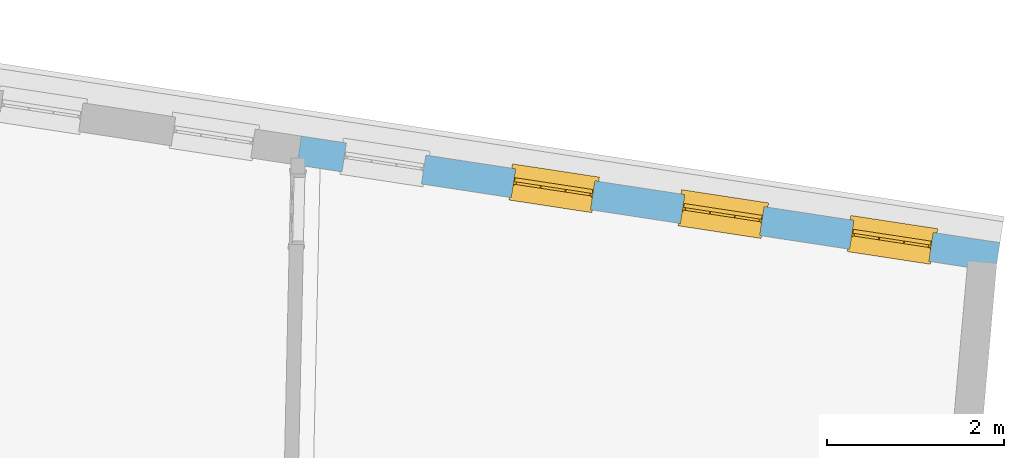
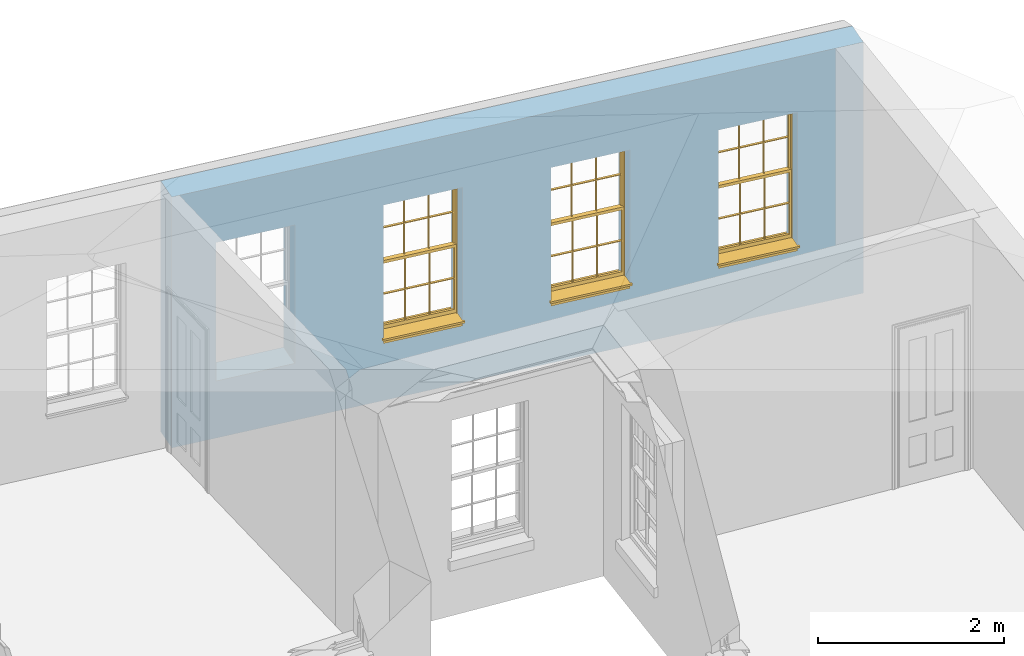
# One storey, part 9 of 12: 3 windows, 4 openings, plus 1 element that does not belong to this part.
"""IFC2X3 building model written with IfcOpenShell, lengths in metres."""

from ifc_helpers import new_model, si_unit, frame, origin, place, context, subcontext, project, spatial, polyline, outline, extrude, faceted_brep, material, layer, layer_set, layer_usage, element, fill, save


model = new_model("IFC2X3")

# Units and contexts
model_context = context("Model", 3, world=origin())
body_context = subcontext(model_context, "Body", "Model", "MODEL_VIEW")
ifc_project = project(units=[si_unit("PLANEANGLEUNIT", "RADIAN"), si_unit("MASSUNIT", "GRAM", prefix="KILO"), si_unit("FORCEUNIT", "NEWTON", prefix="KILO"), si_unit("LENGTHUNIT", "METRE")], contexts=[model_context])

# Site, building, storey
site_placement = place(None, origin())
site = spatial("IfcSite", under=ifc_project, at=site_placement, CompositionType="ELEMENT")
building_placement = place(None, origin())
building = spatial("IfcBuilding", under=site, at=building_placement, Name="Building plot-18", CompositionType="ELEMENT")
storey_placement = place(None, frame((0.0, 0.0, 9.9)))
storey = spatial("IfcBuildingStorey", under=building, at=storey_placement, Name="Floor 2", CompositionType="ELEMENT", Elevation=9.9)

# Wall, openings, windows
ifc_material = material(Name="Masonry")
ifc_layer = layer(ifc_material, 0.33, ventilated=False)
ifc_layer_set = layer_set([ifc_layer], Name="My Wall")
ifc_layer_usage = layer_usage(ifc_layer_set, "AXIS2", "NEGATIVE", 0.08)
wall_placement = place(storey_placement, origin())
wall = element("IfcWallStandardCase", 1, at=wall_placement, inside=storey, material=ifc_layer_usage, Name="exterior", context=body_context, shape_type="SweptSolid", body=[
    extrude(outline(polyline([(101.941775393575, 24.4390124661107), (101.991519769301, 24.7652416755381), (94.0844961381432, 25.9709275645287), (94.0347517624171, 25.6446983551013), (101.941775393575, 24.4390124661107)])), origin(), (0.0, 0.0, 1.0), 3.3),
])
opening_1_placement = place(storey_placement, frame((0.0, 0.0, 0.75)))
opening_1 = element("IfcOpeningElement", 2, at=opening_1_placement, cuts=wall, Name="Opening", ObjectType="Opening", context=body_context, shape_type="SweptSolid", body=[
    extrude(outline(polyline([(101.236692272156, 24.880339960858), (100.337090512825, 25.017513845436), (100.287346137099, 24.6912846360086), (101.186947896429, 24.5541107514306), (101.236692272156, 24.880339960858)])), origin(), (0.0, 0.0, 1.0), 1.82),
])
opening_2_placement = place(storey_placement, frame((0.0, 0.0, 0.75)))
opening_2 = element("IfcOpeningElement", 3, at=opening_2_placement, cuts=wall, Name="Opening", ObjectType="Opening", context=body_context, shape_type="SweptSolid", body=[
    extrude(outline(polyline([(99.3217221994849, 25.1723401498242), (98.4221204401548, 25.3095140344022), (98.3723760644287, 24.9832848249748), (99.2719778237588, 24.8461109403968), (99.3217221994849, 25.1723401498242)])), origin(), (0.0, 0.0, 1.0), 1.82),
])
opening_3_placement = place(storey_placement, frame((0.0, 0.0, 0.75)))
opening_3 = element("IfcOpeningElement", 4, at=opening_3_placement, cuts=wall, Name="Opening", ObjectType="Opening", context=body_context, shape_type="SweptSolid", body=[
    extrude(outline(polyline([(97.4067521268142, 25.4643403387904), (96.5071503674841, 25.6015142233684), (96.4574059917581, 25.275285013941), (97.3570077510882, 25.138111129363), (97.4067521268142, 25.4643403387904)])), origin(), (0.0, 0.0, 1.0), 1.82),
])
opening_4_placement = place(storey_placement, frame((0.0, 0.0, 0.75)))
element("IfcOpeningElement", 5, at=opening_4_placement, cuts=wall, Name="Opening", ObjectType="Opening", context=body_context, shape_type="SweptSolid", body=[
    extrude(outline(polyline([(95.4917820541436, 25.7563405277566), (94.5921802948135, 25.8935144123346), (94.5424359190874, 25.5672852029072), (95.4420376784175, 25.4301113183292), (95.4917820541436, 25.7563405277566)])), origin(), (0.0, 0.0, 1.0), 1.82),
])
window_1_placement = place(storey_placement, frame((101.19900713903, 24.6331966203827, 0.75), z_axis=(0.0, 0.0, 1.0), x_axis=(-0.899601759330096, 0.13717388457793, 0.0)))
window_1 = element("IfcWindow", 6, at=window_1_placement, inside=storey, Name="circulation outside window", OverallHeight=1.82, OverallWidth=0.91, context=body_context, shape_type="Brep", held_by="IfcProductRepresentation", body=[
    faceted_brep([(0.033125, -0.105, 0.975209), (0.01, -0.105, 0.975209), (0.033125, -0.105, 1.376042), (0.876875, -0.105, 0.975209), (0.876875, -0.105, 1.376042), (0.9, -0.105, 0.975209), (0.876875, -0.105, 1.386042), (0.876875, -0.105, 1.786875), (0.9, -0.105, 1.81), (0.033125, -0.105, 1.786875), (0.033125, -0.105, 1.386042), (0.01, -0.105, 1.81), (0.876875, -0.135, 1.376042), (0.876875, -0.135, 0.975209), (0.9, -0.135, 0.937083), (0.033125, -0.135, 1.786875), (0.01, -0.135, 1.81), (0.033125, -0.135, 1.386042), (0.01, -0.135, 0.937083), (0.033125, -0.135, 0.975209), (0.033125, -0.135, 1.376042), (0.876875, -0.135, 1.786875), (0.876875, -0.135, 1.386042), (0.9, -0.135, 1.81), (0.033125, -0.105, 0.937083), (0.01, -0.105, 0.937083), (0.033125, -0.105, 0.53625), (0.876875, -0.105, 0.937083), (0.876875, -0.105, 0.53625), (0.9, -0.105, 0.937083), (0.876875, -0.105, 0.52625), (0.876875, -0.105, 0.125417), (0.9, -0.105, 0.077167), (0.033125, -0.105, 0.125417), (0.033125, -0.105, 0.52625), (0.01, -0.105, 0.077167), (-0.0425, -0.25, 0.01), (-0.0425, -0.3, 0.001667), (0.0, -0.25, 0.01), (0.9525, -0.25, 0.01), (0.91, -0.25, 0.01), (0.9525, -0.3, 0.001667), (-0.02, 0.08, 0.077167), (0.0, 0.08, 0.077167), (-0.02, 0.11, 0.077167), (0.0, -0.06, 0.077167), (0.01, -0.06, 0.077167), (0.91, -0.06, 0.077167), (0.91, 0.08, 0.077167), (0.9, -0.06, 0.077167), (0.93, 0.08, 0.077167), (0.93, 0.11, 0.077167), (0.01, -0.075, 0.975209), (0.9, -0.075, 0.975209), (0.876875, -0.075, 0.125417), (0.876875, -0.075, 0.52625), (0.9, -0.075, 0.077167), (0.876875, -0.075, 0.53625), (0.876875, -0.075, 0.937083), (0.033125, -0.075, 0.125417), (0.01, -0.075, 0.077167), (0.033125, -0.075, 0.52625), (0.033125, -0.075, 0.937083), (0.033125, -0.075, 0.53625), (-0.02, 0.08, 0.052167), (-0.02, 0.11, 0.052167), (0.93, 0.11, 0.052167), (0.93, 0.08, 0.052167), (0.91, 0.08, 0.052167), (0.0, 0.08, 0.052167), (0.91, -0.15, 0.026667), (0.0, -0.15, 0.026667), (-0.0425, -0.3, -0.123333), (0.9525, -0.3, -0.123333), (-0.0425, -0.25, -0.123333), (0.9525, -0.25, -0.123333), (0.01, -0.06, 1.81), (0.9, -0.06, 1.81), (0.0, -0.06, 1.82), (0.91, -0.06, 1.82), (0.01, -0.15, 0.077167), (0.9, -0.15, 0.077167), (0.592292, -0.105, 0.125417), (0.592292, -0.075, 0.125417), (0.317708, -0.075, 0.125417), (0.317708, -0.105, 0.125417), (0.592292, -0.105, 0.53625), (0.317708, -0.105, 0.53625), (0.317708, -0.105, 0.52625), (0.592292, -0.105, 0.52625), (0.592292, -0.075, 0.53625), (0.317708, -0.075, 0.53625), (0.592292, -0.135, 1.386042), (0.592292, -0.105, 1.386042), (0.317708, -0.105, 1.386042), (0.317708, -0.135, 1.386042), (0.317708, -0.135, 1.376042), (0.592292, -0.135, 1.376042), (0.317708, -0.105, 1.376042), (0.592292, -0.105, 1.376042), (0.602292, -0.135, 1.376042), (0.592292, -0.135, 0.975209), (0.602292, -0.135, 0.975209), (0.602292, -0.105, 0.975209), (0.592292, -0.105, 0.975209), (0.602292, -0.105, 1.376042), (0.602292, -0.075, 0.53625), (0.602292, -0.105, 0.53625), (0.317708, -0.075, 0.52625), (0.307708, -0.075, 0.125417), (0.307708, -0.075, 0.52625), (0.602292, -0.075, 0.52625), (0.602292, -0.075, 0.125417), (0.592292, -0.075, 0.52625), (0.307708, -0.075, 0.53625), (0.317708, -0.075, 0.937083), (0.307708, -0.075, 0.937083), (0.602292, -0.075, 0.937083), (0.592292, -0.075, 0.937083), (0.307708, -0.105, 0.52625), (0.307708, -0.105, 0.125417), (0.307708, -0.105, 0.53625), (0.307708, -0.105, 0.937083), (0.592292, -0.105, 0.937083), (0.317708, -0.105, 0.937083), (0.602292, -0.105, 0.937083), (0.602292, -0.105, 0.52625), (0.602292, -0.105, 0.125417), (0.307708, -0.135, 1.386042), (0.307708, -0.135, 1.376042), (0.307708, -0.135, 0.975209), (0.317708, -0.135, 0.975209), (0.317708, -0.135, 1.786875), (0.307708, -0.135, 1.786875), (0.602292, -0.135, 1.786875), (0.592292, -0.135, 1.786875), (0.602292, -0.135, 1.386042), (0.602292, -0.105, 1.386042), (0.307708, -0.105, 1.386042), (0.307708, -0.105, 1.786875), (0.317708, -0.105, 1.786875), (0.592292, -0.105, 1.786875), (0.602292, -0.105, 1.786875), (0.307708, -0.105, 1.376042), (0.317708, -0.105, 0.975209), (0.307708, -0.105, 0.975209), (0.91, -0.15, 1.82), (0.9, -0.15, 1.81), (0.01, -0.15, 1.81), (0.0, -0.15, 1.82), (0.91, -0.25, 0.0), (0.0, -0.25, 0.0), (0.91, 0.08, 0.0), (0.0, 0.08, 0.0)], [[[0, 1, 2]], [[3, 4, 5]], [[6, 7, 8]], [[9, 10, 11]], [[12, 13, 14]], [[15, 16, 17]], [[18, 19, 20]], [[21, 22, 23]], [[24, 25, 26]], [[27, 28, 29]], [[30, 31, 32]], [[33, 34, 35]], [[14, 27, 29]], [[25, 24, 18]], [[36, 37, 38]], [[39, 40, 41]], [[42, 43, 44]], [[45, 46, 43]], [[47, 48, 49]], [[50, 51, 48]], [[1, 0, 52]], [[5, 53, 3]], [[54, 55, 56]], [[57, 58, 53]], [[59, 60, 61]], [[62, 63, 52]], [[48, 43, 46, 49]], [[51, 44, 43, 48]], [[64, 42, 44, 65]], [[65, 44, 51, 66]], [[66, 51, 50, 67]], [[65, 66, 68, 69]], [[60, 56, 49, 46]], [[70, 71, 38, 40]], [[37, 41, 40, 38]], [[37, 72, 73, 41]], [[74, 75, 73, 72]], [[8, 11, 76, 77]], [[76, 78, 79, 77]], [[32, 35, 80, 81]], [[81, 80, 71, 70]], [[82, 83, 84, 85]], [[86, 87, 88, 89]], [[86, 90, 91, 87]], [[92, 93, 94, 95]], [[92, 95, 96, 97]], [[96, 98, 99, 97]], [[100, 97, 101, 102]], [[103, 104, 99, 105]], [[97, 99, 104, 101]], [[102, 103, 105, 100]], [[28, 57, 106, 107]], [[108, 84, 109, 110]], [[111, 112, 83, 113]], [[114, 110, 61, 63]], [[90, 113, 108, 91]], [[115, 91, 114, 116]], [[117, 106, 90, 118]], [[111, 106, 57, 55]], [[119, 110, 109, 120]], [[34, 61, 110, 119]], [[89, 113, 83, 82]], [[88, 108, 113, 89]], [[85, 84, 108, 88]], [[121, 114, 63, 26]], [[122, 116, 114, 121]], [[123, 118, 90, 86]], [[87, 91, 115, 124]], [[107, 106, 117, 125]], [[126, 111, 55, 30]], [[127, 112, 111, 126]], [[126, 30, 28, 107]], [[88, 119, 120, 85]], [[126, 89, 82, 127]], [[125, 123, 86, 107]], [[121, 26, 34, 119]], [[124, 122, 121, 87]], [[128, 17, 20, 129]], [[96, 129, 130, 131]], [[132, 133, 128, 95]], [[134, 135, 92, 136]], [[100, 12, 22, 136]], [[137, 6, 4, 105]], [[94, 138, 139, 140]], [[137, 93, 141, 142]], [[99, 98, 94, 93]], [[143, 2, 10, 138]], [[144, 145, 143, 98]], [[129, 143, 145, 130]], [[20, 2, 143, 129]], [[131, 144, 98, 96]], [[128, 138, 10, 17]], [[133, 139, 138, 128]], [[135, 141, 93, 92]], [[95, 94, 140, 132]], [[22, 6, 137, 136]], [[136, 137, 142, 134]], [[100, 105, 4, 12]], [[107, 86, 89, 126]], [[106, 111, 113, 90]], [[91, 108, 110, 114]], [[87, 121, 119, 88]], [[97, 100, 136, 92]], [[129, 96, 95, 128]], [[98, 143, 138, 94]], [[105, 99, 93, 137]], [[131, 101, 104, 144]], [[124, 115, 118, 123]], [[132, 140, 141, 135]], [[120, 109, 59, 33]], [[15, 9, 139, 133]], [[134, 142, 7, 21]], [[31, 54, 112, 127]], [[36, 74, 72, 37]], [[39, 41, 73, 75]], [[18, 14, 101, 131]], [[23, 16, 132, 135]], [[83, 56, 60, 84]], [[52, 53, 118, 115]], [[53, 52, 144, 104]], [[11, 8, 141, 140]], [[14, 18, 124, 123]], [[2, 1, 11, 10]], [[8, 5, 4, 6]], [[57, 53, 56, 55]], [[60, 52, 63, 61]], [[26, 25, 35, 34]], [[32, 29, 28, 30]], [[14, 23, 22, 12]], [[18, 20, 17, 16]], [[19, 0, 2, 20]], [[17, 10, 9, 15]], [[12, 4, 3, 13]], [[21, 7, 6, 22]], [[27, 58, 57, 28]], [[30, 55, 54, 31]], [[33, 59, 61, 34]], [[26, 63, 62, 24]], [[5, 8, 77, 53]], [[76, 11, 1, 52]], [[46, 45, 78, 76]], [[49, 77, 79, 47]], [[70, 146, 147, 81]], [[71, 80, 148, 149]], [[19, 130, 145, 0]], [[102, 13, 3, 103]], [[116, 122, 24, 62]], [[29, 32, 81, 14]], [[80, 35, 25, 18]], [[60, 46, 76, 52]], [[77, 49, 56, 53]], [[23, 14, 81, 147]], [[16, 148, 80, 18]], [[35, 85, 120]], [[120, 33, 35]], [[127, 82, 32]], [[32, 31, 127]], [[32, 82, 85, 35]], [[102, 101, 14]], [[14, 13, 102]], [[18, 131, 130]], [[130, 19, 18]], [[134, 21, 23]], [[23, 135, 134]], [[16, 15, 133]], [[133, 132, 16]], [[11, 140, 139]], [[139, 9, 11]], [[142, 141, 8]], [[8, 7, 142]], [[23, 147, 148, 16]], [[146, 149, 148, 147]], [[52, 115, 116]], [[116, 62, 52]], [[118, 53, 117]], [[58, 117, 53]], [[27, 125, 117, 58]], [[56, 83, 112]], [[112, 54, 56]], [[109, 84, 60]], [[60, 59, 109]], [[125, 27, 14]], [[14, 123, 125]], [[122, 124, 18]], [[18, 24, 122]], [[145, 144, 52]], [[52, 0, 145]], [[103, 3, 53]], [[53, 104, 103]], [[79, 78, 149, 146]], [[78, 45, 71, 149]], [[146, 70, 47, 79]], [[150, 75, 74, 151]], [[68, 66, 67]], [[48, 68, 67, 50]], [[69, 64, 65]], [[42, 64, 69, 43]], [[69, 68, 152, 153]], [[70, 68, 48, 47]], [[150, 152, 68, 70]], [[43, 69, 71, 45]], [[69, 153, 151, 71]], [[152, 150, 151, 153]], [[38, 151, 74, 36]], [[71, 151, 38]], [[39, 75, 150, 40]], [[40, 150, 70]]]),
])
fill(opening_1, window_1)
window_2_placement = place(storey_placement, frame((99.2840370663591, 24.9251968093489, 0.75), z_axis=(0.0, 0.0, 1.0), x_axis=(-0.899601759330096, 0.13717388457793, 0.0)))
window_2 = element("IfcWindow", 7, at=window_2_placement, inside=storey, Name="circulation outside window", OverallHeight=1.82, OverallWidth=0.91, context=body_context, shape_type="Brep", held_by="IfcProductRepresentation", body=[
    faceted_brep([(0.033125, -0.105, 0.975209), (0.01, -0.105, 0.975209), (0.033125, -0.105, 1.376042), (0.876875, -0.105, 0.975209), (0.876875, -0.105, 1.376042), (0.9, -0.105, 0.975209), (0.876875, -0.105, 1.386042), (0.876875, -0.105, 1.786875), (0.9, -0.105, 1.81), (0.033125, -0.105, 1.786875), (0.033125, -0.105, 1.386042), (0.01, -0.105, 1.81), (0.876875, -0.135, 1.376042), (0.876875, -0.135, 0.975209), (0.9, -0.135, 0.937083), (0.033125, -0.135, 1.786875), (0.01, -0.135, 1.81), (0.033125, -0.135, 1.386042), (0.01, -0.135, 0.937083), (0.033125, -0.135, 0.975209), (0.033125, -0.135, 1.376042), (0.876875, -0.135, 1.786875), (0.876875, -0.135, 1.386042), (0.9, -0.135, 1.81), (0.033125, -0.105, 0.937083), (0.01, -0.105, 0.937083), (0.033125, -0.105, 0.53625), (0.876875, -0.105, 0.937083), (0.876875, -0.105, 0.53625), (0.9, -0.105, 0.937083), (0.876875, -0.105, 0.52625), (0.876875, -0.105, 0.125417), (0.9, -0.105, 0.077167), (0.033125, -0.105, 0.125417), (0.033125, -0.105, 0.52625), (0.01, -0.105, 0.077167), (-0.0425, -0.25, 0.01), (-0.0425, -0.3, 0.001667), (0.0, -0.25, 0.01), (0.9525, -0.25, 0.01), (0.91, -0.25, 0.01), (0.9525, -0.3, 0.001667), (-0.02, 0.08, 0.077167), (0.0, 0.08, 0.077167), (-0.02, 0.11, 0.077167), (0.0, -0.06, 0.077167), (0.01, -0.06, 0.077167), (0.91, -0.06, 0.077167), (0.91, 0.08, 0.077167), (0.9, -0.06, 0.077167), (0.93, 0.08, 0.077167), (0.93, 0.11, 0.077167), (0.01, -0.075, 0.975209), (0.9, -0.075, 0.975209), (0.876875, -0.075, 0.125417), (0.876875, -0.075, 0.52625), (0.9, -0.075, 0.077167), (0.876875, -0.075, 0.53625), (0.876875, -0.075, 0.937083), (0.033125, -0.075, 0.125417), (0.01, -0.075, 0.077167), (0.033125, -0.075, 0.52625), (0.033125, -0.075, 0.937083), (0.033125, -0.075, 0.53625), (-0.02, 0.08, 0.052167), (-0.02, 0.11, 0.052167), (0.93, 0.11, 0.052167), (0.93, 0.08, 0.052167), (0.91, 0.08, 0.052167), (0.0, 0.08, 0.052167), (0.91, -0.15, 0.026667), (0.0, -0.15, 0.026667), (-0.0425, -0.3, -0.123333), (0.9525, -0.3, -0.123333), (-0.0425, -0.25, -0.123333), (0.9525, -0.25, -0.123333), (0.01, -0.06, 1.81), (0.9, -0.06, 1.81), (0.0, -0.06, 1.82), (0.91, -0.06, 1.82), (0.01, -0.15, 0.077167), (0.9, -0.15, 0.077167), (0.592292, -0.105, 0.125417), (0.592292, -0.075, 0.125417), (0.317708, -0.075, 0.125417), (0.317708, -0.105, 0.125417), (0.592292, -0.105, 0.53625), (0.317708, -0.105, 0.53625), (0.317708, -0.105, 0.52625), (0.592292, -0.105, 0.52625), (0.592292, -0.075, 0.53625), (0.317708, -0.075, 0.53625), (0.592292, -0.135, 1.386042), (0.592292, -0.105, 1.386042), (0.317708, -0.105, 1.386042), (0.317708, -0.135, 1.386042), (0.317708, -0.135, 1.376042), (0.592292, -0.135, 1.376042), (0.317708, -0.105, 1.376042), (0.592292, -0.105, 1.376042), (0.602292, -0.135, 1.376042), (0.592292, -0.135, 0.975209), (0.602292, -0.135, 0.975209), (0.602292, -0.105, 0.975209), (0.592292, -0.105, 0.975209), (0.602292, -0.105, 1.376042), (0.602292, -0.075, 0.53625), (0.602292, -0.105, 0.53625), (0.317708, -0.075, 0.52625), (0.307708, -0.075, 0.125417), (0.307708, -0.075, 0.52625), (0.602292, -0.075, 0.52625), (0.602292, -0.075, 0.125417), (0.592292, -0.075, 0.52625), (0.307708, -0.075, 0.53625), (0.317708, -0.075, 0.937083), (0.307708, -0.075, 0.937083), (0.602292, -0.075, 0.937083), (0.592292, -0.075, 0.937083), (0.307708, -0.105, 0.52625), (0.307708, -0.105, 0.125417), (0.307708, -0.105, 0.53625), (0.307708, -0.105, 0.937083), (0.592292, -0.105, 0.937083), (0.317708, -0.105, 0.937083), (0.602292, -0.105, 0.937083), (0.602292, -0.105, 0.52625), (0.602292, -0.105, 0.125417), (0.307708, -0.135, 1.386042), (0.307708, -0.135, 1.376042), (0.307708, -0.135, 0.975209), (0.317708, -0.135, 0.975209), (0.317708, -0.135, 1.786875), (0.307708, -0.135, 1.786875), (0.602292, -0.135, 1.786875), (0.592292, -0.135, 1.786875), (0.602292, -0.135, 1.386042), (0.602292, -0.105, 1.386042), (0.307708, -0.105, 1.386042), (0.307708, -0.105, 1.786875), (0.317708, -0.105, 1.786875), (0.592292, -0.105, 1.786875), (0.602292, -0.105, 1.786875), (0.307708, -0.105, 1.376042), (0.317708, -0.105, 0.975209), (0.307708, -0.105, 0.975209), (0.91, -0.15, 1.82), (0.9, -0.15, 1.81), (0.01, -0.15, 1.81), (0.0, -0.15, 1.82), (0.91, -0.25, 0.0), (0.0, -0.25, 0.0), (0.91, 0.08, 0.0), (0.0, 0.08, 0.0)], [[[0, 1, 2]], [[3, 4, 5]], [[6, 7, 8]], [[9, 10, 11]], [[12, 13, 14]], [[15, 16, 17]], [[18, 19, 20]], [[21, 22, 23]], [[24, 25, 26]], [[27, 28, 29]], [[30, 31, 32]], [[33, 34, 35]], [[14, 27, 29]], [[25, 24, 18]], [[36, 37, 38]], [[39, 40, 41]], [[42, 43, 44]], [[45, 46, 43]], [[47, 48, 49]], [[50, 51, 48]], [[1, 0, 52]], [[5, 53, 3]], [[54, 55, 56]], [[57, 58, 53]], [[59, 60, 61]], [[62, 63, 52]], [[48, 43, 46, 49]], [[51, 44, 43, 48]], [[64, 42, 44, 65]], [[65, 44, 51, 66]], [[66, 51, 50, 67]], [[65, 66, 68, 69]], [[60, 56, 49, 46]], [[70, 71, 38, 40]], [[37, 41, 40, 38]], [[37, 72, 73, 41]], [[74, 75, 73, 72]], [[8, 11, 76, 77]], [[76, 78, 79, 77]], [[32, 35, 80, 81]], [[81, 80, 71, 70]], [[82, 83, 84, 85]], [[86, 87, 88, 89]], [[86, 90, 91, 87]], [[92, 93, 94, 95]], [[92, 95, 96, 97]], [[96, 98, 99, 97]], [[100, 97, 101, 102]], [[103, 104, 99, 105]], [[97, 99, 104, 101]], [[102, 103, 105, 100]], [[28, 57, 106, 107]], [[108, 84, 109, 110]], [[111, 112, 83, 113]], [[114, 110, 61, 63]], [[90, 113, 108, 91]], [[115, 91, 114, 116]], [[117, 106, 90, 118]], [[111, 106, 57, 55]], [[119, 110, 109, 120]], [[34, 61, 110, 119]], [[89, 113, 83, 82]], [[88, 108, 113, 89]], [[85, 84, 108, 88]], [[121, 114, 63, 26]], [[122, 116, 114, 121]], [[123, 118, 90, 86]], [[87, 91, 115, 124]], [[107, 106, 117, 125]], [[126, 111, 55, 30]], [[127, 112, 111, 126]], [[126, 30, 28, 107]], [[88, 119, 120, 85]], [[126, 89, 82, 127]], [[125, 123, 86, 107]], [[121, 26, 34, 119]], [[124, 122, 121, 87]], [[128, 17, 20, 129]], [[96, 129, 130, 131]], [[132, 133, 128, 95]], [[134, 135, 92, 136]], [[100, 12, 22, 136]], [[137, 6, 4, 105]], [[94, 138, 139, 140]], [[137, 93, 141, 142]], [[99, 98, 94, 93]], [[143, 2, 10, 138]], [[144, 145, 143, 98]], [[129, 143, 145, 130]], [[20, 2, 143, 129]], [[131, 144, 98, 96]], [[128, 138, 10, 17]], [[133, 139, 138, 128]], [[135, 141, 93, 92]], [[95, 94, 140, 132]], [[22, 6, 137, 136]], [[136, 137, 142, 134]], [[100, 105, 4, 12]], [[107, 86, 89, 126]], [[106, 111, 113, 90]], [[91, 108, 110, 114]], [[87, 121, 119, 88]], [[97, 100, 136, 92]], [[129, 96, 95, 128]], [[98, 143, 138, 94]], [[105, 99, 93, 137]], [[131, 101, 104, 144]], [[124, 115, 118, 123]], [[132, 140, 141, 135]], [[120, 109, 59, 33]], [[15, 9, 139, 133]], [[134, 142, 7, 21]], [[31, 54, 112, 127]], [[36, 74, 72, 37]], [[39, 41, 73, 75]], [[18, 14, 101, 131]], [[23, 16, 132, 135]], [[83, 56, 60, 84]], [[52, 53, 118, 115]], [[53, 52, 144, 104]], [[11, 8, 141, 140]], [[14, 18, 124, 123]], [[2, 1, 11, 10]], [[8, 5, 4, 6]], [[57, 53, 56, 55]], [[60, 52, 63, 61]], [[26, 25, 35, 34]], [[32, 29, 28, 30]], [[14, 23, 22, 12]], [[18, 20, 17, 16]], [[19, 0, 2, 20]], [[17, 10, 9, 15]], [[12, 4, 3, 13]], [[21, 7, 6, 22]], [[27, 58, 57, 28]], [[30, 55, 54, 31]], [[33, 59, 61, 34]], [[26, 63, 62, 24]], [[5, 8, 77, 53]], [[76, 11, 1, 52]], [[46, 45, 78, 76]], [[49, 77, 79, 47]], [[70, 146, 147, 81]], [[71, 80, 148, 149]], [[19, 130, 145, 0]], [[102, 13, 3, 103]], [[116, 122, 24, 62]], [[29, 32, 81, 14]], [[80, 35, 25, 18]], [[60, 46, 76, 52]], [[77, 49, 56, 53]], [[23, 14, 81, 147]], [[16, 148, 80, 18]], [[35, 85, 120]], [[120, 33, 35]], [[127, 82, 32]], [[32, 31, 127]], [[32, 82, 85, 35]], [[102, 101, 14]], [[14, 13, 102]], [[18, 131, 130]], [[130, 19, 18]], [[134, 21, 23]], [[23, 135, 134]], [[16, 15, 133]], [[133, 132, 16]], [[11, 140, 139]], [[139, 9, 11]], [[142, 141, 8]], [[8, 7, 142]], [[23, 147, 148, 16]], [[146, 149, 148, 147]], [[52, 115, 116]], [[116, 62, 52]], [[118, 53, 117]], [[58, 117, 53]], [[27, 125, 117, 58]], [[56, 83, 112]], [[112, 54, 56]], [[109, 84, 60]], [[60, 59, 109]], [[125, 27, 14]], [[14, 123, 125]], [[122, 124, 18]], [[18, 24, 122]], [[145, 144, 52]], [[52, 0, 145]], [[103, 3, 53]], [[53, 104, 103]], [[79, 78, 149, 146]], [[78, 45, 71, 149]], [[146, 70, 47, 79]], [[150, 75, 74, 151]], [[68, 66, 67]], [[48, 68, 67, 50]], [[69, 64, 65]], [[42, 64, 69, 43]], [[69, 68, 152, 153]], [[70, 68, 48, 47]], [[150, 152, 68, 70]], [[43, 69, 71, 45]], [[69, 153, 151, 71]], [[152, 150, 151, 153]], [[38, 151, 74, 36]], [[71, 151, 38]], [[39, 75, 150, 40]], [[40, 150, 70]]]),
])
fill(opening_2, window_2)
window_3_placement = place(storey_placement, frame((97.3690669936884, 25.2171969983151, 0.75), z_axis=(0.0, 0.0, 1.0), x_axis=(-0.899601759330096, 0.13717388457793, 0.0)))
window_3 = element("IfcWindow", 8, at=window_3_placement, inside=storey, Name="circulation outside window", OverallHeight=1.82, OverallWidth=0.91, context=body_context, shape_type="Brep", held_by="IfcProductRepresentation", body=[
    faceted_brep([(0.033125, -0.105, 0.975209), (0.01, -0.105, 0.975209), (0.033125, -0.105, 1.376042), (0.876875, -0.105, 0.975209), (0.876875, -0.105, 1.376042), (0.9, -0.105, 0.975209), (0.876875, -0.105, 1.386042), (0.876875, -0.105, 1.786875), (0.9, -0.105, 1.81), (0.033125, -0.105, 1.786875), (0.033125, -0.105, 1.386042), (0.01, -0.105, 1.81), (0.876875, -0.135, 1.376042), (0.876875, -0.135, 0.975209), (0.9, -0.135, 0.937083), (0.033125, -0.135, 1.786875), (0.01, -0.135, 1.81), (0.033125, -0.135, 1.386042), (0.01, -0.135, 0.937083), (0.033125, -0.135, 0.975209), (0.033125, -0.135, 1.376042), (0.876875, -0.135, 1.786875), (0.876875, -0.135, 1.386042), (0.9, -0.135, 1.81), (0.033125, -0.105, 0.937083), (0.01, -0.105, 0.937083), (0.033125, -0.105, 0.53625), (0.876875, -0.105, 0.937083), (0.876875, -0.105, 0.53625), (0.9, -0.105, 0.937083), (0.876875, -0.105, 0.52625), (0.876875, -0.105, 0.125417), (0.9, -0.105, 0.077167), (0.033125, -0.105, 0.125417), (0.033125, -0.105, 0.52625), (0.01, -0.105, 0.077167), (-0.0425, -0.25, 0.01), (-0.0425, -0.3, 0.001667), (0.0, -0.25, 0.01), (0.9525, -0.25, 0.01), (0.91, -0.25, 0.01), (0.9525, -0.3, 0.001667), (-0.02, 0.08, 0.077167), (0.0, 0.08, 0.077167), (-0.02, 0.11, 0.077167), (0.0, -0.06, 0.077167), (0.01, -0.06, 0.077167), (0.91, -0.06, 0.077167), (0.91, 0.08, 0.077167), (0.9, -0.06, 0.077167), (0.93, 0.08, 0.077167), (0.93, 0.11, 0.077167), (0.01, -0.075, 0.975209), (0.9, -0.075, 0.975209), (0.876875, -0.075, 0.125417), (0.876875, -0.075, 0.52625), (0.9, -0.075, 0.077167), (0.876875, -0.075, 0.53625), (0.876875, -0.075, 0.937083), (0.033125, -0.075, 0.125417), (0.01, -0.075, 0.077167), (0.033125, -0.075, 0.52625), (0.033125, -0.075, 0.937083), (0.033125, -0.075, 0.53625), (-0.02, 0.08, 0.052167), (-0.02, 0.11, 0.052167), (0.93, 0.11, 0.052167), (0.93, 0.08, 0.052167), (0.91, 0.08, 0.052167), (0.0, 0.08, 0.052167), (0.91, -0.15, 0.026667), (0.0, -0.15, 0.026667), (-0.0425, -0.3, -0.123333), (0.9525, -0.3, -0.123333), (-0.0425, -0.25, -0.123333), (0.9525, -0.25, -0.123333), (0.01, -0.06, 1.81), (0.9, -0.06, 1.81), (0.0, -0.06, 1.82), (0.91, -0.06, 1.82), (0.01, -0.15, 0.077167), (0.9, -0.15, 0.077167), (0.592292, -0.105, 0.125417), (0.592292, -0.075, 0.125417), (0.317708, -0.075, 0.125417), (0.317708, -0.105, 0.125417), (0.592292, -0.105, 0.53625), (0.317708, -0.105, 0.53625), (0.317708, -0.105, 0.52625), (0.592292, -0.105, 0.52625), (0.592292, -0.075, 0.53625), (0.317708, -0.075, 0.53625), (0.592292, -0.135, 1.386042), (0.592292, -0.105, 1.386042), (0.317708, -0.105, 1.386042), (0.317708, -0.135, 1.386042), (0.317708, -0.135, 1.376042), (0.592292, -0.135, 1.376042), (0.317708, -0.105, 1.376042), (0.592292, -0.105, 1.376042), (0.602292, -0.135, 1.376042), (0.592292, -0.135, 0.975209), (0.602292, -0.135, 0.975209), (0.602292, -0.105, 0.975209), (0.592292, -0.105, 0.975209), (0.602292, -0.105, 1.376042), (0.602292, -0.075, 0.53625), (0.602292, -0.105, 0.53625), (0.317708, -0.075, 0.52625), (0.307708, -0.075, 0.125417), (0.307708, -0.075, 0.52625), (0.602292, -0.075, 0.52625), (0.602292, -0.075, 0.125417), (0.592292, -0.075, 0.52625), (0.307708, -0.075, 0.53625), (0.317708, -0.075, 0.937083), (0.307708, -0.075, 0.937083), (0.602292, -0.075, 0.937083), (0.592292, -0.075, 0.937083), (0.307708, -0.105, 0.52625), (0.307708, -0.105, 0.125417), (0.307708, -0.105, 0.53625), (0.307708, -0.105, 0.937083), (0.592292, -0.105, 0.937083), (0.317708, -0.105, 0.937083), (0.602292, -0.105, 0.937083), (0.602292, -0.105, 0.52625), (0.602292, -0.105, 0.125417), (0.307708, -0.135, 1.386042), (0.307708, -0.135, 1.376042), (0.307708, -0.135, 0.975209), (0.317708, -0.135, 0.975209), (0.317708, -0.135, 1.786875), (0.307708, -0.135, 1.786875), (0.602292, -0.135, 1.786875), (0.592292, -0.135, 1.786875), (0.602292, -0.135, 1.386042), (0.602292, -0.105, 1.386042), (0.307708, -0.105, 1.386042), (0.307708, -0.105, 1.786875), (0.317708, -0.105, 1.786875), (0.592292, -0.105, 1.786875), (0.602292, -0.105, 1.786875), (0.307708, -0.105, 1.376042), (0.317708, -0.105, 0.975209), (0.307708, -0.105, 0.975209), (0.91, -0.15, 1.82), (0.9, -0.15, 1.81), (0.01, -0.15, 1.81), (0.0, -0.15, 1.82), (0.91, -0.25, 0.0), (0.0, -0.25, 0.0), (0.91, 0.08, 0.0), (0.0, 0.08, 0.0)], [[[0, 1, 2]], [[3, 4, 5]], [[6, 7, 8]], [[9, 10, 11]], [[12, 13, 14]], [[15, 16, 17]], [[18, 19, 20]], [[21, 22, 23]], [[24, 25, 26]], [[27, 28, 29]], [[30, 31, 32]], [[33, 34, 35]], [[14, 27, 29]], [[25, 24, 18]], [[36, 37, 38]], [[39, 40, 41]], [[42, 43, 44]], [[45, 46, 43]], [[47, 48, 49]], [[50, 51, 48]], [[1, 0, 52]], [[5, 53, 3]], [[54, 55, 56]], [[57, 58, 53]], [[59, 60, 61]], [[62, 63, 52]], [[48, 43, 46, 49]], [[51, 44, 43, 48]], [[64, 42, 44, 65]], [[65, 44, 51, 66]], [[66, 51, 50, 67]], [[65, 66, 68, 69]], [[60, 56, 49, 46]], [[70, 71, 38, 40]], [[37, 41, 40, 38]], [[37, 72, 73, 41]], [[74, 75, 73, 72]], [[8, 11, 76, 77]], [[76, 78, 79, 77]], [[32, 35, 80, 81]], [[81, 80, 71, 70]], [[82, 83, 84, 85]], [[86, 87, 88, 89]], [[86, 90, 91, 87]], [[92, 93, 94, 95]], [[92, 95, 96, 97]], [[96, 98, 99, 97]], [[100, 97, 101, 102]], [[103, 104, 99, 105]], [[97, 99, 104, 101]], [[102, 103, 105, 100]], [[28, 57, 106, 107]], [[108, 84, 109, 110]], [[111, 112, 83, 113]], [[114, 110, 61, 63]], [[90, 113, 108, 91]], [[115, 91, 114, 116]], [[117, 106, 90, 118]], [[111, 106, 57, 55]], [[119, 110, 109, 120]], [[34, 61, 110, 119]], [[89, 113, 83, 82]], [[88, 108, 113, 89]], [[85, 84, 108, 88]], [[121, 114, 63, 26]], [[122, 116, 114, 121]], [[123, 118, 90, 86]], [[87, 91, 115, 124]], [[107, 106, 117, 125]], [[126, 111, 55, 30]], [[127, 112, 111, 126]], [[126, 30, 28, 107]], [[88, 119, 120, 85]], [[126, 89, 82, 127]], [[125, 123, 86, 107]], [[121, 26, 34, 119]], [[124, 122, 121, 87]], [[128, 17, 20, 129]], [[96, 129, 130, 131]], [[132, 133, 128, 95]], [[134, 135, 92, 136]], [[100, 12, 22, 136]], [[137, 6, 4, 105]], [[94, 138, 139, 140]], [[137, 93, 141, 142]], [[99, 98, 94, 93]], [[143, 2, 10, 138]], [[144, 145, 143, 98]], [[129, 143, 145, 130]], [[20, 2, 143, 129]], [[131, 144, 98, 96]], [[128, 138, 10, 17]], [[133, 139, 138, 128]], [[135, 141, 93, 92]], [[95, 94, 140, 132]], [[22, 6, 137, 136]], [[136, 137, 142, 134]], [[100, 105, 4, 12]], [[107, 86, 89, 126]], [[106, 111, 113, 90]], [[91, 108, 110, 114]], [[87, 121, 119, 88]], [[97, 100, 136, 92]], [[129, 96, 95, 128]], [[98, 143, 138, 94]], [[105, 99, 93, 137]], [[131, 101, 104, 144]], [[124, 115, 118, 123]], [[132, 140, 141, 135]], [[120, 109, 59, 33]], [[15, 9, 139, 133]], [[134, 142, 7, 21]], [[31, 54, 112, 127]], [[36, 74, 72, 37]], [[39, 41, 73, 75]], [[18, 14, 101, 131]], [[23, 16, 132, 135]], [[83, 56, 60, 84]], [[52, 53, 118, 115]], [[53, 52, 144, 104]], [[11, 8, 141, 140]], [[14, 18, 124, 123]], [[2, 1, 11, 10]], [[8, 5, 4, 6]], [[57, 53, 56, 55]], [[60, 52, 63, 61]], [[26, 25, 35, 34]], [[32, 29, 28, 30]], [[14, 23, 22, 12]], [[18, 20, 17, 16]], [[19, 0, 2, 20]], [[17, 10, 9, 15]], [[12, 4, 3, 13]], [[21, 7, 6, 22]], [[27, 58, 57, 28]], [[30, 55, 54, 31]], [[33, 59, 61, 34]], [[26, 63, 62, 24]], [[5, 8, 77, 53]], [[76, 11, 1, 52]], [[46, 45, 78, 76]], [[49, 77, 79, 47]], [[70, 146, 147, 81]], [[71, 80, 148, 149]], [[19, 130, 145, 0]], [[102, 13, 3, 103]], [[116, 122, 24, 62]], [[29, 32, 81, 14]], [[80, 35, 25, 18]], [[60, 46, 76, 52]], [[77, 49, 56, 53]], [[23, 14, 81, 147]], [[16, 148, 80, 18]], [[35, 85, 120]], [[120, 33, 35]], [[127, 82, 32]], [[32, 31, 127]], [[32, 82, 85, 35]], [[102, 101, 14]], [[14, 13, 102]], [[18, 131, 130]], [[130, 19, 18]], [[134, 21, 23]], [[23, 135, 134]], [[16, 15, 133]], [[133, 132, 16]], [[11, 140, 139]], [[139, 9, 11]], [[142, 141, 8]], [[8, 7, 142]], [[23, 147, 148, 16]], [[146, 149, 148, 147]], [[52, 115, 116]], [[116, 62, 52]], [[118, 53, 117]], [[58, 117, 53]], [[27, 125, 117, 58]], [[56, 83, 112]], [[112, 54, 56]], [[109, 84, 60]], [[60, 59, 109]], [[125, 27, 14]], [[14, 123, 125]], [[122, 124, 18]], [[18, 24, 122]], [[145, 144, 52]], [[52, 0, 145]], [[103, 3, 53]], [[53, 104, 103]], [[79, 78, 149, 146]], [[78, 45, 71, 149]], [[146, 70, 47, 79]], [[150, 75, 74, 151]], [[68, 66, 67]], [[48, 68, 67, 50]], [[69, 64, 65]], [[42, 64, 69, 43]], [[69, 68, 152, 153]], [[70, 68, 48, 47]], [[150, 152, 68, 70]], [[43, 69, 71, 45]], [[69, 153, 151, 71]], [[152, 150, 151, 153]], [[38, 151, 74, 36]], [[71, 151, 38]], [[39, 75, 150, 40]], [[40, 150, 70]]]),
])
fill(opening_3, window_3)

save(model, "model.ifc")
